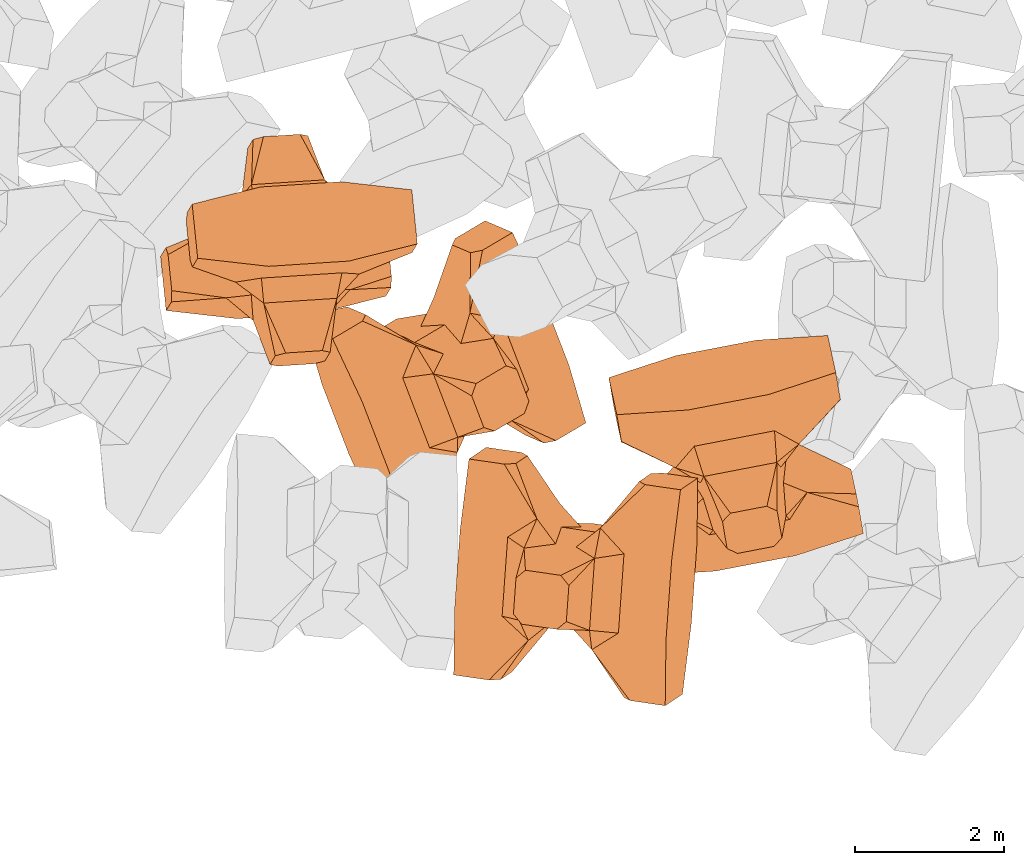
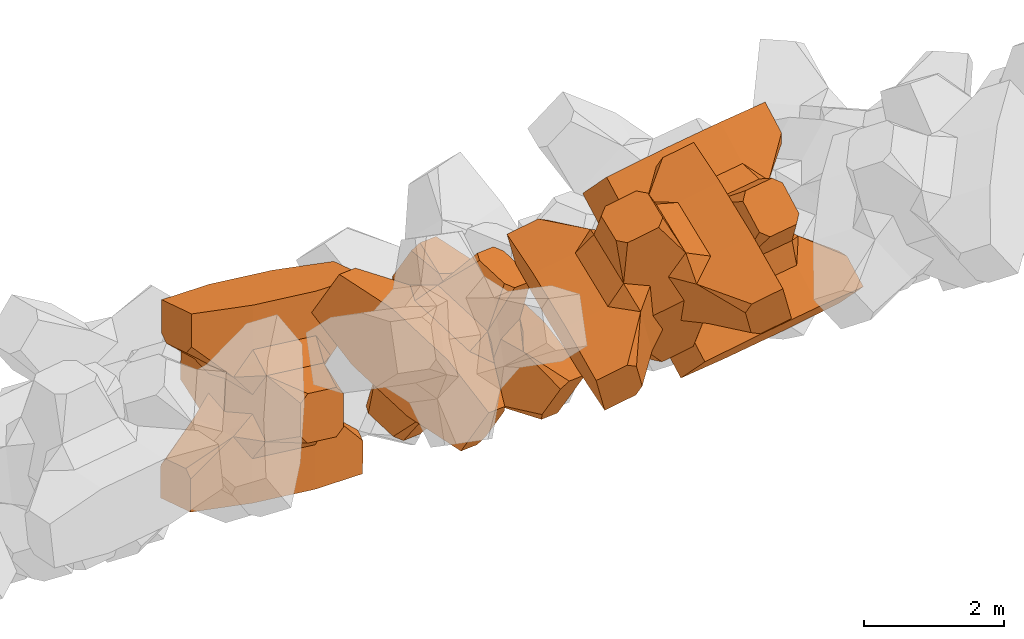
# One storey, part 13 of 17: 4 civil elements.
"""IFC4 building model written with IfcOpenShell, lengths in metres."""

from ifc_helpers import new_model, entity, si_unit, converted_unit, frame, origin_with_axes, origin_2d_with_axis, place, context, subcontext, project, spatial, polygons, element, save


model = new_model("IFC4")

# Units and contexts
model_context = context("Model", 3, precision=1e-05, world=origin_with_axes())
plan_context = context("Plan", 2, precision=1e-05, world=origin_2d_with_axis())
body_context = subcontext(model_context, "Body", "Model", "MODEL_VIEW")
ifc_project = project(units=[si_unit("VOLUMEUNIT", "CUBIC_METRE"), si_unit("LENGTHUNIT", "METRE"), converted_unit("PLANEANGLEUNIT", "degree", entity("IfcReal", 0.0174532925199433), si_unit("PLANEANGLEUNIT", "RADIAN"), dimensions=[0, 0, 0, 0, 0, 0, 0]), si_unit("AREAUNIT", "SQUARE_METRE")], contexts=[model_context, plan_context])

# Site, building, storey
site_placement = place(None, origin_with_axes())
site = spatial("IfcSite", under=ifc_project, at=site_placement)
building_placement = place(site_placement, origin_with_axes())
building = spatial("IfcBuilding", under=site, at=building_placement, Name="Building")
storey_placement = place(building_placement, origin_with_axes())
storey = spatial("IfcBuildingStorey", under=building, at=storey_placement, Name="Storey")

# Civil elements
civil_element_1_placement = place(storey_placement, frame((10.4306650161743, 16.4936103820801, 4.91588735580444), z_axis=(0.0997602614041295, -0.969936522886138, 0.221970790457051), x_axis=(-0.984893169041668, -0.064523959364222, 0.160692576813695)))
element("IfcCivilElement", 1, at=civil_element_1_placement, inside=storey, ObjectType="IfcCivilElementType", context=body_context, shape_type="Tessellation", body=[
    polygons([(0.50000011920929, 0.500000059604645, 0.821428716182709), (0.374999821186066, 0.249999940395355, 1.50000023841858), (0.550000011920929, 0.145680621266365, 0.550000131130219), (0.374999821186066, -0.250000029802322, 1.50000023841858), (0.651315808296204, -0.250000029802322, 1.45970560083697e-07), (0.651315808296204, 0.249999940395355, 1.45970560083697e-07), (0.550000011920929, -0.145680695772171, 0.550000131130219), (0.50000011920929, -0.500000059604645, 0.821428716182709), (-0.25, 0.374999791383743, 1.50000023841858), (0.249999970197678, 0.374999791383743, 1.50000023841858), (-0.500000059604645, 0.500000059604645, 0.821428716182709), (-0.550000011920929, 0.824999988079071, 0.550000131130219), (0.550000011920929, 0.824999988079071, 0.550000131130219), (-0.550000011920929, 1.5, 0.550000131130219), (0.550000011920929, 1.5, 0.550000131130219), (-0.25, -0.375, 1.50000023841858), (0.249999970197678, -0.375, 1.50000023841858), (-0.374999970197678, -0.250000029802322, 1.50000023841858), (-0.374999970197678, 0.249999940395355, 1.50000023841858), (1.5, 0.87499988079071, -0.249999836087227), (1.5, 0.87499988079071, 0.25000011920929), (0.845557510852814, 0.449999898672104, -0.49555516242981), (0.845557510852814, 0.449999898672104, 0.49555516242981), (1.5, 1.5, -0.374999821186066), (1.5, 1.5, 0.374999970197678), (1.5, 1.0, -0.374999821186066), (1.5, 1.0, 0.374999970197678), (-1.5, 1.5, -0.374999821186066), (-1.5, 1.5, 0.374999970197678), (-0.550000011920929, 1.5, -0.549999833106995), (0.550000011920929, 1.5, -0.549999833106995), (0.550000011920929, 0.145680621266365, -0.549999833106995), (-0.500000059604645, -0.500000059604645, 0.821428716182709), (-0.550000011920929, -0.145680695772171, 0.550000131130219), (-0.651315808296204, 0.249999940395355, 1.45970560083697e-07), (-0.651315808296204, -0.250000029802322, 1.45970560083697e-07), (-0.550000011920929, 0.145680621266365, 0.550000131130219), (-1.5, 0.87499988079071, 0.25000011920929), (-1.5, 0.87499988079071, -0.249999836087227), (-0.845557391643524, 0.449999898672104, 0.49555516242981), (-0.845557391643524, 0.449999898672104, -0.49555516242981), (-1.5, 1.0, 0.374999970197678), (-1.5, 1.0, -0.374999821186066), (-0.550000011920929, 0.145680621266365, -0.549999833106995), (0.550000011920929, -0.825000107288361, 0.550000131130219), (-0.550000011920929, -0.825000107288361, 0.550000131130219), (0.550000011920929, -1.5, 0.550000131130219), (-0.550000011920929, -1.5, 0.550000131130219), (1.5, -0.875000059604645, 0.25000011920929), (1.5, -0.875000059604645, -0.249999836087227), (0.845557510852814, -0.450000137090683, 0.49555516242981), (0.845557510852814, -0.450000137090683, -0.49555516242981), (1.5, -1.5, 0.374999970197678), (1.5, -1.5, -0.374999821186066), (1.5, -1.00000011920929, 0.374999970197678), (1.5, -1.00000011920929, -0.374999821186066), (0.550000011920929, -1.5, -0.549999833106995), (-0.550000011920929, -1.5, -0.549999833106995), (-1.5, -1.5, -0.374999821186066), (-1.5, -1.5, 0.374999970197678), (0.550000011920929, -0.145680695772171, -0.549999833106995), (-1.5, -0.875000059604645, -0.249999836087227), (-1.5, -0.875000059604645, 0.25000011920929), (-0.845557391643524, -0.450000137090683, -0.49555516242981), (-0.845557391643524, -0.450000137090683, 0.49555516242981), (-1.5, -1.00000011920929, -0.374999821186066), (-1.5, -1.00000011920929, 0.374999970197678), (-0.550000011920929, -0.145680695772171, -0.549999833106995), (0.50000011920929, -0.500000059604645, -0.821428537368774), (0.374999821186066, -0.250000029802322, -1.49999988079071), (0.374999821186066, 0.249999940395355, -1.49999988079071), (0.50000011920929, 0.500000059604645, -0.821428537368774), (0.249999970197678, 0.374999791383743, -1.49999988079071), (-0.25, 0.374999791383743, -1.49999988079071), (-0.500000059604645, 0.500000059604645, -0.821428537368774), (0.550000011920929, 0.824999988079071, -0.549999833106995), (-0.550000011920929, 0.824999988079071, -0.549999833106995), (0.249999970197678, -0.375, -1.49999988079071), (-0.25, -0.375, -1.49999988079071), (-0.374999970197678, -0.250000029802322, -1.49999988079071), (-0.374999970197678, 0.249999940395355, -1.49999988079071), (-0.500000059604645, -0.500000059604645, -0.821428537368774), (-0.550000011920929, -0.825000107288361, -0.549999833106995), (0.550000011920929, -0.825000107288361, -0.549999833106995)], [[[1, 2, 3]], [[3, 2, 4]], [[5, 6, 7]], [[7, 6, 3]], [[7, 3, 8]], [[8, 3, 4]], [[9, 10, 11]], [[11, 10, 1]], [[12, 13, 14]], [[14, 13, 15]], [[16, 17, 18]], [[18, 17, 4]], [[18, 4, 19]], [[19, 4, 2]], [[19, 2, 9]], [[9, 2, 10]], [[20, 21, 22]], [[22, 21, 23]], [[24, 25, 26]], [[26, 25, 27]], [[26, 27, 20]], [[20, 27, 21]], [[23, 27, 13]], [[13, 27, 25]], [[13, 25, 15]], [[28, 29, 30]], [[30, 29, 14]], [[30, 14, 31]], [[31, 14, 15]], [[31, 15, 24]], [[24, 15, 25]], [[21, 27, 23]], [[2, 1, 10]], [[13, 12, 1]], [[1, 12, 11]], [[13, 1, 23]], [[32, 22, 6]], [[6, 22, 23]], [[6, 23, 3]], [[3, 23, 1]], [[33, 18, 34]], [[34, 18, 19]], [[35, 36, 37]], [[37, 36, 34]], [[37, 34, 11]], [[11, 34, 19]], [[38, 39, 40]], [[40, 39, 41]], [[29, 28, 42]], [[42, 28, 43]], [[42, 43, 38]], [[38, 43, 39]], [[14, 29, 12]], [[12, 29, 42]], [[12, 42, 40]], [[40, 42, 38]], [[9, 11, 19]], [[40, 11, 12]], [[37, 40, 35]], [[35, 40, 41]], [[35, 41, 44]], [[11, 40, 37]], [[17, 16, 8]], [[8, 16, 33]], [[45, 46, 47]], [[47, 46, 48]], [[49, 50, 51]], [[51, 50, 52]], [[53, 54, 55]], [[55, 54, 56]], [[55, 56, 49]], [[49, 56, 50]], [[47, 53, 45]], [[45, 53, 55]], [[45, 55, 51]], [[54, 53, 57]], [[57, 53, 47]], [[57, 47, 58]], [[58, 47, 48]], [[58, 48, 59]], [[59, 48, 60]], [[51, 55, 49]], [[17, 8, 4]], [[46, 45, 33]], [[33, 45, 8]], [[51, 8, 45]], [[7, 51, 5]], [[5, 51, 52]], [[5, 52, 61]], [[8, 51, 7]], [[62, 63, 64]], [[64, 63, 65]], [[59, 60, 66]], [[66, 60, 67]], [[66, 67, 62]], [[62, 67, 63]], [[65, 67, 46]], [[46, 67, 60]], [[46, 60, 48]], [[63, 67, 65]], [[18, 33, 16]], [[46, 33, 65]], [[68, 64, 36]], [[36, 64, 65]], [[36, 65, 34]], [[34, 65, 33]], [[69, 70, 61]], [[61, 70, 71]], [[6, 5, 32]], [[32, 5, 61]], [[32, 61, 72]], [[72, 61, 71]], [[73, 74, 72]], [[72, 74, 75]], [[76, 77, 31]], [[31, 77, 30]], [[78, 79, 70]], [[70, 79, 80]], [[70, 80, 71]], [[71, 80, 81]], [[71, 81, 73]], [[73, 81, 74]], [[31, 24, 76]], [[76, 24, 26]], [[76, 26, 22]], [[22, 26, 20]], [[73, 72, 71]], [[77, 76, 75]], [[75, 76, 72]], [[22, 72, 76]], [[72, 22, 32]], [[75, 81, 44]], [[44, 81, 80]], [[36, 35, 68]], [[68, 35, 44]], [[68, 44, 82]], [[82, 44, 80]], [[41, 43, 77]], [[77, 43, 28]], [[77, 28, 30]], [[39, 43, 41]], [[81, 75, 74]], [[77, 75, 41]], [[44, 41, 75]], [[79, 78, 82]], [[82, 78, 69]], [[83, 84, 58]], [[58, 84, 57]], [[52, 56, 84]], [[84, 56, 54]], [[84, 54, 57]], [[50, 56, 52]], [[70, 69, 78]], [[84, 83, 69]], [[69, 83, 82]], [[84, 69, 52]], [[61, 52, 69]], [[58, 59, 83]], [[83, 59, 66]], [[83, 66, 64]], [[64, 66, 62]], [[79, 82, 80]], [[64, 82, 83]], [[82, 64, 68]]], closed=True),
])
civil_element_2_placement = place(storey_placement, frame((12.5372552871704, 14.8145837783813, 5.94786405563354), z_axis=(0.490738916016187, -0.210224980806438, 0.845565357469303), x_axis=(0.329233076234966, -0.853769113405119, -0.403340901110088)))
element("IfcCivilElement", 2, at=civil_element_2_placement, inside=storey, ObjectType="IfcCivilElementType", context=body_context, shape_type="Tessellation", body=[
    polygons([(0.50000011920929, 0.500000059604645, 0.821428716182709), (0.374999821186066, 0.249999940395355, 1.50000023841858), (0.550000011920929, 0.145680621266365, 0.550000131130219), (0.374999821186066, -0.250000029802322, 1.50000023841858), (0.651315808296204, -0.250000029802322, 1.45970560083697e-07), (0.651315808296204, 0.249999940395355, 1.45970560083697e-07), (0.550000011920929, -0.145680695772171, 0.550000131130219), (0.50000011920929, -0.500000059604645, 0.821428716182709), (-0.25, 0.374999791383743, 1.50000023841858), (0.249999970197678, 0.374999791383743, 1.50000023841858), (-0.500000059604645, 0.500000059604645, 0.821428716182709), (-0.550000011920929, 0.824999988079071, 0.550000131130219), (0.550000011920929, 0.824999988079071, 0.550000131130219), (-0.550000011920929, 1.5, 0.550000131130219), (0.550000011920929, 1.5, 0.550000131130219), (-0.25, -0.375, 1.50000023841858), (0.249999970197678, -0.375, 1.50000023841858), (-0.374999970197678, -0.250000029802322, 1.50000023841858), (-0.374999970197678, 0.249999940395355, 1.50000023841858), (1.5, 0.87499988079071, -0.249999836087227), (1.5, 0.87499988079071, 0.25000011920929), (0.845557510852814, 0.449999898672104, -0.49555516242981), (0.845557510852814, 0.449999898672104, 0.49555516242981), (1.5, 1.5, -0.374999821186066), (1.5, 1.5, 0.374999970197678), (1.5, 1.0, -0.374999821186066), (1.5, 1.0, 0.374999970197678), (-1.5, 1.5, -0.374999821186066), (-1.5, 1.5, 0.374999970197678), (-0.550000011920929, 1.5, -0.549999833106995), (0.550000011920929, 1.5, -0.549999833106995), (0.550000011920929, 0.145680621266365, -0.549999833106995), (-0.500000059604645, -0.500000059604645, 0.821428716182709), (-0.550000011920929, -0.145680695772171, 0.550000131130219), (-0.651315808296204, 0.249999940395355, 1.45970560083697e-07), (-0.651315808296204, -0.250000029802322, 1.45970560083697e-07), (-0.550000011920929, 0.145680621266365, 0.550000131130219), (-1.5, 0.87499988079071, 0.25000011920929), (-1.5, 0.87499988079071, -0.249999836087227), (-0.845557391643524, 0.449999898672104, 0.49555516242981), (-0.845557391643524, 0.449999898672104, -0.49555516242981), (-1.5, 1.0, 0.374999970197678), (-1.5, 1.0, -0.374999821186066), (-0.550000011920929, 0.145680621266365, -0.549999833106995), (0.550000011920929, -0.825000107288361, 0.550000131130219), (-0.550000011920929, -0.825000107288361, 0.550000131130219), (0.550000011920929, -1.5, 0.550000131130219), (-0.550000011920929, -1.5, 0.550000131130219), (1.5, -0.875000059604645, 0.25000011920929), (1.5, -0.875000059604645, -0.249999836087227), (0.845557510852814, -0.450000137090683, 0.49555516242981), (0.845557510852814, -0.450000137090683, -0.49555516242981), (1.5, -1.5, 0.374999970197678), (1.5, -1.5, -0.374999821186066), (1.5, -1.00000011920929, 0.374999970197678), (1.5, -1.00000011920929, -0.374999821186066), (0.550000011920929, -1.5, -0.549999833106995), (-0.550000011920929, -1.5, -0.549999833106995), (-1.5, -1.5, -0.374999821186066), (-1.5, -1.5, 0.374999970197678), (0.550000011920929, -0.145680695772171, -0.549999833106995), (-1.5, -0.875000059604645, -0.249999836087227), (-1.5, -0.875000059604645, 0.25000011920929), (-0.845557391643524, -0.450000137090683, -0.49555516242981), (-0.845557391643524, -0.450000137090683, 0.49555516242981), (-1.5, -1.00000011920929, -0.374999821186066), (-1.5, -1.00000011920929, 0.374999970197678), (-0.550000011920929, -0.145680695772171, -0.549999833106995), (0.50000011920929, -0.500000059604645, -0.821428537368774), (0.374999821186066, -0.250000029802322, -1.49999988079071), (0.374999821186066, 0.249999940395355, -1.49999988079071), (0.50000011920929, 0.500000059604645, -0.821428537368774), (0.249999970197678, 0.374999791383743, -1.49999988079071), (-0.25, 0.374999791383743, -1.49999988079071), (-0.500000059604645, 0.500000059604645, -0.821428537368774), (0.550000011920929, 0.824999988079071, -0.549999833106995), (-0.550000011920929, 0.824999988079071, -0.549999833106995), (0.249999970197678, -0.375, -1.49999988079071), (-0.25, -0.375, -1.49999988079071), (-0.374999970197678, -0.250000029802322, -1.49999988079071), (-0.374999970197678, 0.249999940395355, -1.49999988079071), (-0.500000059604645, -0.500000059604645, -0.821428537368774), (-0.550000011920929, -0.825000107288361, -0.549999833106995), (0.550000011920929, -0.825000107288361, -0.549999833106995)], [[[1, 2, 3]], [[3, 2, 4]], [[5, 6, 7]], [[7, 6, 3]], [[7, 3, 8]], [[8, 3, 4]], [[9, 10, 11]], [[11, 10, 1]], [[12, 13, 14]], [[14, 13, 15]], [[16, 17, 18]], [[18, 17, 4]], [[18, 4, 19]], [[19, 4, 2]], [[19, 2, 9]], [[9, 2, 10]], [[20, 21, 22]], [[22, 21, 23]], [[24, 25, 26]], [[26, 25, 27]], [[26, 27, 20]], [[20, 27, 21]], [[23, 27, 13]], [[13, 27, 25]], [[13, 25, 15]], [[28, 29, 30]], [[30, 29, 14]], [[30, 14, 31]], [[31, 14, 15]], [[31, 15, 24]], [[24, 15, 25]], [[21, 27, 23]], [[2, 1, 10]], [[13, 12, 1]], [[1, 12, 11]], [[13, 1, 23]], [[32, 22, 6]], [[6, 22, 23]], [[6, 23, 3]], [[3, 23, 1]], [[33, 18, 34]], [[34, 18, 19]], [[35, 36, 37]], [[37, 36, 34]], [[37, 34, 11]], [[11, 34, 19]], [[38, 39, 40]], [[40, 39, 41]], [[29, 28, 42]], [[42, 28, 43]], [[42, 43, 38]], [[38, 43, 39]], [[14, 29, 12]], [[12, 29, 42]], [[12, 42, 40]], [[40, 42, 38]], [[9, 11, 19]], [[40, 11, 12]], [[37, 40, 35]], [[35, 40, 41]], [[35, 41, 44]], [[11, 40, 37]], [[17, 16, 8]], [[8, 16, 33]], [[45, 46, 47]], [[47, 46, 48]], [[49, 50, 51]], [[51, 50, 52]], [[53, 54, 55]], [[55, 54, 56]], [[55, 56, 49]], [[49, 56, 50]], [[47, 53, 45]], [[45, 53, 55]], [[45, 55, 51]], [[54, 53, 57]], [[57, 53, 47]], [[57, 47, 58]], [[58, 47, 48]], [[58, 48, 59]], [[59, 48, 60]], [[51, 55, 49]], [[17, 8, 4]], [[46, 45, 33]], [[33, 45, 8]], [[51, 8, 45]], [[7, 51, 5]], [[5, 51, 52]], [[5, 52, 61]], [[8, 51, 7]], [[62, 63, 64]], [[64, 63, 65]], [[59, 60, 66]], [[66, 60, 67]], [[66, 67, 62]], [[62, 67, 63]], [[65, 67, 46]], [[46, 67, 60]], [[46, 60, 48]], [[63, 67, 65]], [[18, 33, 16]], [[46, 33, 65]], [[68, 64, 36]], [[36, 64, 65]], [[36, 65, 34]], [[34, 65, 33]], [[69, 70, 61]], [[61, 70, 71]], [[6, 5, 32]], [[32, 5, 61]], [[32, 61, 72]], [[72, 61, 71]], [[73, 74, 72]], [[72, 74, 75]], [[76, 77, 31]], [[31, 77, 30]], [[78, 79, 70]], [[70, 79, 80]], [[70, 80, 71]], [[71, 80, 81]], [[71, 81, 73]], [[73, 81, 74]], [[31, 24, 76]], [[76, 24, 26]], [[76, 26, 22]], [[22, 26, 20]], [[73, 72, 71]], [[77, 76, 75]], [[75, 76, 72]], [[22, 72, 76]], [[72, 22, 32]], [[75, 81, 44]], [[44, 81, 80]], [[36, 35, 68]], [[68, 35, 44]], [[68, 44, 82]], [[82, 44, 80]], [[41, 43, 77]], [[77, 43, 28]], [[77, 28, 30]], [[39, 43, 41]], [[81, 75, 74]], [[77, 75, 41]], [[44, 41, 75]], [[79, 78, 82]], [[82, 78, 69]], [[83, 84, 58]], [[58, 84, 57]], [[52, 56, 84]], [[84, 56, 54]], [[84, 54, 57]], [[50, 56, 52]], [[70, 69, 78]], [[84, 83, 69]], [[69, 83, 82]], [[84, 69, 52]], [[61, 52, 69]], [[58, 59, 83]], [[83, 59, 66]], [[83, 66, 64]], [[64, 66, 62]], [[79, 82, 80]], [[64, 82, 83]], [[82, 64, 68]]], closed=True),
])
civil_element_3_placement = place(storey_placement, frame((16.4453239440918, 13.7304496765137, 7.04668760299683), z_axis=(0.143883514367067, -0.665460600159223, 0.732434108933431), x_axis=(-0.981795325083321, -0.188733252614976, 0.0213939010446142)))
element("IfcCivilElement", 3, at=civil_element_3_placement, inside=storey, ObjectType="IfcCivilElementType", context=body_context, shape_type="Tessellation", body=[
    polygons([(0.500000059604645, 0.499999791383743, 0.821428656578064), (0.374999791383743, 0.249999806284904, 1.5), (0.549999952316284, 0.145680546760559, 0.550000071525574), (0.374999791383743, -0.24999988079071, 1.5), (0.651315748691559, -0.24999988079071, 1.45970545872842e-07), (0.651315748691559, 0.249999806284904, 1.45970545872842e-07), (0.549999952316284, -0.145680621266365, 0.550000071525574), (0.500000059604645, -0.499999791383743, 0.821428656578064), (-0.249999970197678, 0.374999582767487, 1.5), (0.249999940395355, 0.374999582767487, 1.5), (-0.5, 0.499999791383743, 0.821428656578064), (-0.549999952316284, 0.824999511241913, 0.550000071525574), (0.549999952316284, 0.824999511241913, 0.550000071525574), (-0.549999952316284, 1.49999916553497, 0.550000071525574), (0.549999952316284, 1.49999916553497, 0.550000071525574), (-0.249999970197678, -0.374999791383743, 1.5), (0.249999940395355, -0.374999791383743, 1.5), (-0.374999940395355, -0.24999988079071, 1.5), (-0.374999940395355, 0.249999806284904, 1.5), (1.49999988079071, 0.874999344348907, -0.249999806284904), (1.49999988079071, 0.874999344348907, 0.25000011920929), (0.845557451248169, 0.449999630451202, -0.495555102825165), (0.845557451248169, 0.449999630451202, 0.495555102825165), (1.49999988079071, 1.49999916553497, -0.374999791383743), (1.49999988079071, 1.49999916553497, 0.374999940395355), (1.49999988079071, 0.999999403953552, -0.374999791383743), (1.49999988079071, 0.999999403953552, 0.374999940395355), (-1.49999988079071, 1.49999916553497, -0.374999791383743), (-1.49999988079071, 1.49999916553497, 0.374999940395355), (-0.549999952316284, 1.49999916553497, -0.54999977350235), (0.549999952316284, 1.49999916553497, -0.54999977350235), (0.549999952316284, 0.145680546760559, -0.54999977350235), (-0.5, -0.499999791383743, 0.821428656578064), (-0.549999952316284, -0.145680621266365, 0.550000071525574), (-0.651315748691559, 0.249999806284904, 1.45970545872842e-07), (-0.651315748691559, -0.24999988079071, 1.45970545872842e-07), (-0.549999952316284, 0.145680546760559, 0.550000071525574), (-1.49999988079071, 0.874999344348907, 0.25000011920929), (-1.49999988079071, 0.874999344348907, -0.249999806284904), (-0.845557332038879, 0.449999630451202, 0.495555102825165), (-0.845557332038879, 0.449999630451202, -0.495555102825165), (-1.49999988079071, 0.999999403953552, 0.374999940395355), (-1.49999988079071, 0.999999403953552, -0.374999791383743), (-0.549999952316284, 0.145680546760559, -0.54999977350235), (0.549999952316284, -0.824999630451202, 0.550000071525574), (-0.549999952316284, -0.824999630451202, 0.550000071525574), (0.549999952316284, -1.49999916553497, 0.550000071525574), (-0.549999952316284, -1.49999916553497, 0.550000071525574), (1.49999988079071, -0.874999582767487, 0.25000011920929), (1.49999988079071, -0.874999582767487, -0.249999806284904), (0.845557451248169, -0.449999868869781, 0.495555102825165), (0.845557451248169, -0.449999868869781, -0.495555102825165), (1.49999988079071, -1.49999916553497, 0.374999940395355), (1.49999988079071, -1.49999916553497, -0.374999791383743), (1.49999988079071, -0.999999582767487, 0.374999940395355), (1.49999988079071, -0.999999582767487, -0.374999791383743), (0.549999952316284, -1.49999916553497, -0.54999977350235), (-0.549999952316284, -1.49999916553497, -0.54999977350235), (-1.49999988079071, -1.49999916553497, -0.374999791383743), (-1.49999988079071, -1.49999916553497, 0.374999940395355), (0.549999952316284, -0.145680621266365, -0.54999977350235), (-1.49999988079071, -0.874999582767487, -0.249999806284904), (-1.49999988079071, -0.874999582767487, 0.25000011920929), (-0.845557332038879, -0.449999868869781, -0.495555102825165), (-0.845557332038879, -0.449999868869781, 0.495555102825165), (-1.49999988079071, -0.999999582767487, -0.374999791383743), (-1.49999988079071, -0.999999582767487, 0.374999940395355), (-0.549999952316284, -0.145680621266365, -0.54999977350235), (0.500000059604645, -0.499999791383743, -0.821428418159485), (0.374999791383743, -0.24999988079071, -1.49999976158142), (0.374999791383743, 0.249999806284904, -1.49999976158142), (0.500000059604645, 0.499999791383743, -0.821428418159485), (0.249999940395355, 0.374999582767487, -1.49999976158142), (-0.249999970197678, 0.374999582767487, -1.49999976158142), (-0.5, 0.499999791383743, -0.821428418159485), (0.549999952316284, 0.824999511241913, -0.54999977350235), (-0.549999952316284, 0.824999511241913, -0.54999977350235), (0.249999940395355, -0.374999791383743, -1.49999976158142), (-0.249999970197678, -0.374999791383743, -1.49999976158142), (-0.374999940395355, -0.24999988079071, -1.49999976158142), (-0.374999940395355, 0.249999806284904, -1.49999976158142), (-0.5, -0.499999791383743, -0.821428418159485), (-0.549999952316284, -0.824999630451202, -0.54999977350235), (0.549999952316284, -0.824999630451202, -0.54999977350235)], [[[1, 2, 3]], [[3, 2, 4]], [[5, 6, 7]], [[7, 6, 3]], [[7, 3, 8]], [[8, 3, 4]], [[9, 10, 11]], [[11, 10, 1]], [[12, 13, 14]], [[14, 13, 15]], [[16, 17, 18]], [[18, 17, 4]], [[18, 4, 19]], [[19, 4, 2]], [[19, 2, 9]], [[9, 2, 10]], [[20, 21, 22]], [[22, 21, 23]], [[24, 25, 26]], [[26, 25, 27]], [[26, 27, 20]], [[20, 27, 21]], [[23, 27, 13]], [[13, 27, 25]], [[13, 25, 15]], [[28, 29, 30]], [[30, 29, 14]], [[30, 14, 31]], [[31, 14, 15]], [[31, 15, 24]], [[24, 15, 25]], [[21, 27, 23]], [[2, 1, 10]], [[13, 12, 1]], [[1, 12, 11]], [[13, 1, 23]], [[32, 22, 6]], [[6, 22, 23]], [[6, 23, 3]], [[3, 23, 1]], [[33, 18, 34]], [[34, 18, 19]], [[35, 36, 37]], [[37, 36, 34]], [[37, 34, 11]], [[11, 34, 19]], [[38, 39, 40]], [[40, 39, 41]], [[29, 28, 42]], [[42, 28, 43]], [[42, 43, 38]], [[38, 43, 39]], [[14, 29, 12]], [[12, 29, 42]], [[12, 42, 40]], [[40, 42, 38]], [[9, 11, 19]], [[40, 11, 12]], [[37, 40, 35]], [[35, 40, 41]], [[35, 41, 44]], [[11, 40, 37]], [[17, 16, 8]], [[8, 16, 33]], [[45, 46, 47]], [[47, 46, 48]], [[49, 50, 51]], [[51, 50, 52]], [[53, 54, 55]], [[55, 54, 56]], [[55, 56, 49]], [[49, 56, 50]], [[47, 53, 45]], [[45, 53, 55]], [[45, 55, 51]], [[54, 53, 57]], [[57, 53, 47]], [[57, 47, 58]], [[58, 47, 48]], [[58, 48, 59]], [[59, 48, 60]], [[51, 55, 49]], [[17, 8, 4]], [[46, 45, 33]], [[33, 45, 8]], [[51, 8, 45]], [[7, 51, 5]], [[5, 51, 52]], [[5, 52, 61]], [[8, 51, 7]], [[62, 63, 64]], [[64, 63, 65]], [[59, 60, 66]], [[66, 60, 67]], [[66, 67, 62]], [[62, 67, 63]], [[65, 67, 46]], [[46, 67, 60]], [[46, 60, 48]], [[63, 67, 65]], [[18, 33, 16]], [[46, 33, 65]], [[68, 64, 36]], [[36, 64, 65]], [[36, 65, 34]], [[34, 65, 33]], [[69, 70, 61]], [[61, 70, 71]], [[6, 5, 32]], [[32, 5, 61]], [[32, 61, 72]], [[72, 61, 71]], [[73, 74, 72]], [[72, 74, 75]], [[76, 77, 31]], [[31, 77, 30]], [[78, 79, 70]], [[70, 79, 80]], [[70, 80, 71]], [[71, 80, 81]], [[71, 81, 73]], [[73, 81, 74]], [[31, 24, 76]], [[76, 24, 26]], [[76, 26, 22]], [[22, 26, 20]], [[73, 72, 71]], [[77, 76, 75]], [[75, 76, 72]], [[22, 72, 76]], [[72, 22, 32]], [[75, 81, 44]], [[44, 81, 80]], [[36, 35, 68]], [[68, 35, 44]], [[68, 44, 82]], [[82, 44, 80]], [[41, 43, 77]], [[77, 43, 28]], [[77, 28, 30]], [[39, 43, 41]], [[81, 75, 74]], [[77, 75, 41]], [[44, 41, 75]], [[79, 78, 82]], [[82, 78, 69]], [[83, 84, 58]], [[58, 84, 57]], [[52, 56, 84]], [[84, 56, 54]], [[84, 54, 57]], [[50, 56, 52]], [[70, 69, 78]], [[84, 83, 69]], [[69, 83, 82]], [[84, 69, 52]], [[61, 52, 69]], [[58, 59, 83]], [[83, 59, 66]], [[83, 66, 64]], [[64, 66, 62]], [[79, 82, 80]], [[64, 82, 83]], [[82, 64, 68]]], closed=True),
])
civil_element_4_placement = place(storey_placement, frame((14.2880563735962, 12.1036577224731, 8.15471172332764), z_axis=(-0.310037318203178, -0.208340155323289, 0.927615890873614), x_axis=(-0.0684992222858571, -0.96826290926048, -0.240363880599113)))
element("IfcCivilElement", 4, at=civil_element_4_placement, inside=storey, ObjectType="IfcCivilElementType", context=body_context, shape_type="Tessellation", body=[
    polygons([(0.5, 0.500000059604645, 0.821428716182709), (0.374999761581421, 0.249999940395355, 1.50000023841858), (0.549999892711639, 0.145680621266365, 0.550000131130219), (0.374999761581421, -0.250000029802322, 1.50000023841858), (0.651315689086914, -0.250000029802322, 1.45970560083697e-07), (0.651315689086914, 0.249999940395355, 1.45970560083697e-07), (0.549999892711639, -0.145680695772171, 0.550000131130219), (0.5, -0.500000059604645, 0.821428716182709), (-0.249999955296516, 0.374999791383743, 1.50000023841858), (0.249999910593033, 0.374999791383743, 1.50000023841858), (-0.499999940395355, 0.500000059604645, 0.821428716182709), (-0.549999892711639, 0.824999988079071, 0.550000131130219), (0.549999892711639, 0.824999988079071, 0.550000131130219), (-0.549999892711639, 1.5, 0.550000131130219), (0.549999892711639, 1.5, 0.550000131130219), (-0.249999955296516, -0.375, 1.50000023841858), (0.249999910593033, -0.375, 1.50000023841858), (-0.374999910593033, -0.250000029802322, 1.50000023841858), (-0.374999910593033, 0.249999940395355, 1.50000023841858), (1.49999976158142, 0.87499988079071, -0.249999836087227), (1.49999976158142, 0.87499988079071, 0.25000011920929), (0.845557391643524, 0.449999898672104, -0.49555516242981), (0.845557391643524, 0.449999898672104, 0.49555516242981), (1.49999976158142, 1.5, -0.374999821186066), (1.49999976158142, 1.5, 0.374999970197678), (1.49999976158142, 1.0, -0.374999821186066), (1.49999976158142, 1.0, 0.374999970197678), (-1.49999976158142, 1.5, -0.374999821186066), (-1.49999976158142, 1.5, 0.374999970197678), (-0.549999892711639, 1.5, -0.549999833106995), (0.549999892711639, 1.5, -0.549999833106995), (0.549999892711639, 0.145680621266365, -0.549999833106995), (-0.499999940395355, -0.500000059604645, 0.821428716182709), (-0.549999892711639, -0.145680695772171, 0.550000131130219), (-0.651315689086914, 0.249999940395355, 1.45970560083697e-07), (-0.651315689086914, -0.250000029802322, 1.45970560083697e-07), (-0.549999892711639, 0.145680621266365, 0.550000131130219), (-1.49999976158142, 0.87499988079071, 0.25000011920929), (-1.49999976158142, 0.87499988079071, -0.249999836087227), (-0.84555721282959, 0.449999898672104, 0.49555516242981), (-0.84555721282959, 0.449999898672104, -0.49555516242981), (-1.49999976158142, 1.0, 0.374999970197678), (-1.49999976158142, 1.0, -0.374999821186066), (-0.549999892711639, 0.145680621266365, -0.549999833106995), (0.549999892711639, -0.825000107288361, 0.550000131130219), (-0.549999892711639, -0.825000107288361, 0.550000131130219), (0.549999892711639, -1.5, 0.550000131130219), (-0.549999892711639, -1.5, 0.550000131130219), (1.49999976158142, -0.875000059604645, 0.25000011920929), (1.49999976158142, -0.875000059604645, -0.249999836087227), (0.845557391643524, -0.450000137090683, 0.49555516242981), (0.845557391643524, -0.450000137090683, -0.49555516242981), (1.49999976158142, -1.5, 0.374999970197678), (1.49999976158142, -1.5, -0.374999821186066), (1.49999976158142, -1.00000011920929, 0.374999970197678), (1.49999976158142, -1.00000011920929, -0.374999821186066), (0.549999892711639, -1.5, -0.549999833106995), (-0.549999892711639, -1.5, -0.549999833106995), (-1.49999976158142, -1.5, -0.374999821186066), (-1.49999976158142, -1.5, 0.374999970197678), (0.549999892711639, -0.145680695772171, -0.549999833106995), (-1.49999976158142, -0.875000059604645, -0.249999836087227), (-1.49999976158142, -0.875000059604645, 0.25000011920929), (-0.84555721282959, -0.450000137090683, -0.49555516242981), (-0.84555721282959, -0.450000137090683, 0.49555516242981), (-1.49999976158142, -1.00000011920929, -0.374999821186066), (-1.49999976158142, -1.00000011920929, 0.374999970197678), (-0.549999892711639, -0.145680695772171, -0.549999833106995), (0.5, -0.500000059604645, -0.821428537368774), (0.374999761581421, -0.250000029802322, -1.49999988079071), (0.374999761581421, 0.249999940395355, -1.49999988079071), (0.5, 0.500000059604645, -0.821428537368774), (0.249999910593033, 0.374999791383743, -1.49999988079071), (-0.249999955296516, 0.374999791383743, -1.49999988079071), (-0.499999940395355, 0.500000059604645, -0.821428537368774), (0.549999892711639, 0.824999988079071, -0.549999833106995), (-0.549999892711639, 0.824999988079071, -0.549999833106995), (0.249999910593033, -0.375, -1.49999988079071), (-0.249999955296516, -0.375, -1.49999988079071), (-0.374999910593033, -0.250000029802322, -1.49999988079071), (-0.374999910593033, 0.249999940395355, -1.49999988079071), (-0.499999940395355, -0.500000059604645, -0.821428537368774), (-0.549999892711639, -0.825000107288361, -0.549999833106995), (0.549999892711639, -0.825000107288361, -0.549999833106995)], [[[1, 2, 3]], [[3, 2, 4]], [[5, 6, 7]], [[7, 6, 3]], [[7, 3, 8]], [[8, 3, 4]], [[9, 10, 11]], [[11, 10, 1]], [[12, 13, 14]], [[14, 13, 15]], [[16, 17, 18]], [[18, 17, 4]], [[18, 4, 19]], [[19, 4, 2]], [[19, 2, 9]], [[9, 2, 10]], [[20, 21, 22]], [[22, 21, 23]], [[24, 25, 26]], [[26, 25, 27]], [[26, 27, 20]], [[20, 27, 21]], [[23, 27, 13]], [[13, 27, 25]], [[13, 25, 15]], [[28, 29, 30]], [[30, 29, 14]], [[30, 14, 31]], [[31, 14, 15]], [[31, 15, 24]], [[24, 15, 25]], [[21, 27, 23]], [[2, 1, 10]], [[13, 12, 1]], [[1, 12, 11]], [[13, 1, 23]], [[32, 22, 6]], [[6, 22, 23]], [[6, 23, 3]], [[3, 23, 1]], [[33, 18, 34]], [[34, 18, 19]], [[35, 36, 37]], [[37, 36, 34]], [[37, 34, 11]], [[11, 34, 19]], [[38, 39, 40]], [[40, 39, 41]], [[29, 28, 42]], [[42, 28, 43]], [[42, 43, 38]], [[38, 43, 39]], [[14, 29, 12]], [[12, 29, 42]], [[12, 42, 40]], [[40, 42, 38]], [[9, 11, 19]], [[40, 11, 12]], [[37, 40, 35]], [[35, 40, 41]], [[35, 41, 44]], [[11, 40, 37]], [[17, 16, 8]], [[8, 16, 33]], [[45, 46, 47]], [[47, 46, 48]], [[49, 50, 51]], [[51, 50, 52]], [[53, 54, 55]], [[55, 54, 56]], [[55, 56, 49]], [[49, 56, 50]], [[47, 53, 45]], [[45, 53, 55]], [[45, 55, 51]], [[54, 53, 57]], [[57, 53, 47]], [[57, 47, 58]], [[58, 47, 48]], [[58, 48, 59]], [[59, 48, 60]], [[51, 55, 49]], [[17, 8, 4]], [[46, 45, 33]], [[33, 45, 8]], [[51, 8, 45]], [[7, 51, 5]], [[5, 51, 52]], [[5, 52, 61]], [[8, 51, 7]], [[62, 63, 64]], [[64, 63, 65]], [[59, 60, 66]], [[66, 60, 67]], [[66, 67, 62]], [[62, 67, 63]], [[65, 67, 46]], [[46, 67, 60]], [[46, 60, 48]], [[63, 67, 65]], [[18, 33, 16]], [[46, 33, 65]], [[68, 64, 36]], [[36, 64, 65]], [[36, 65, 34]], [[34, 65, 33]], [[69, 70, 61]], [[61, 70, 71]], [[6, 5, 32]], [[32, 5, 61]], [[32, 61, 72]], [[72, 61, 71]], [[73, 74, 72]], [[72, 74, 75]], [[76, 77, 31]], [[31, 77, 30]], [[78, 79, 70]], [[70, 79, 80]], [[70, 80, 71]], [[71, 80, 81]], [[71, 81, 73]], [[73, 81, 74]], [[31, 24, 76]], [[76, 24, 26]], [[76, 26, 22]], [[22, 26, 20]], [[73, 72, 71]], [[77, 76, 75]], [[75, 76, 72]], [[22, 72, 76]], [[72, 22, 32]], [[75, 81, 44]], [[44, 81, 80]], [[36, 35, 68]], [[68, 35, 44]], [[68, 44, 82]], [[82, 44, 80]], [[41, 43, 77]], [[77, 43, 28]], [[77, 28, 30]], [[39, 43, 41]], [[81, 75, 74]], [[77, 75, 41]], [[44, 41, 75]], [[79, 78, 82]], [[82, 78, 69]], [[83, 84, 58]], [[58, 84, 57]], [[52, 56, 84]], [[84, 56, 54]], [[84, 54, 57]], [[50, 56, 52]], [[70, 69, 78]], [[84, 83, 69]], [[69, 83, 82]], [[84, 69, 52]], [[61, 52, 69]], [[58, 59, 83]], [[83, 59, 66]], [[83, 66, 64]], [[64, 66, 62]], [[79, 82, 80]], [[64, 82, 83]], [[82, 64, 68]]], closed=True),
])

save(model, "model.ifc")
